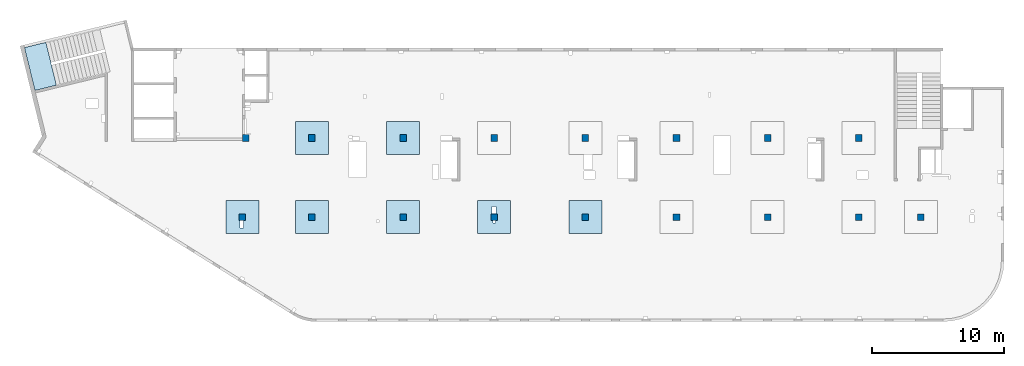
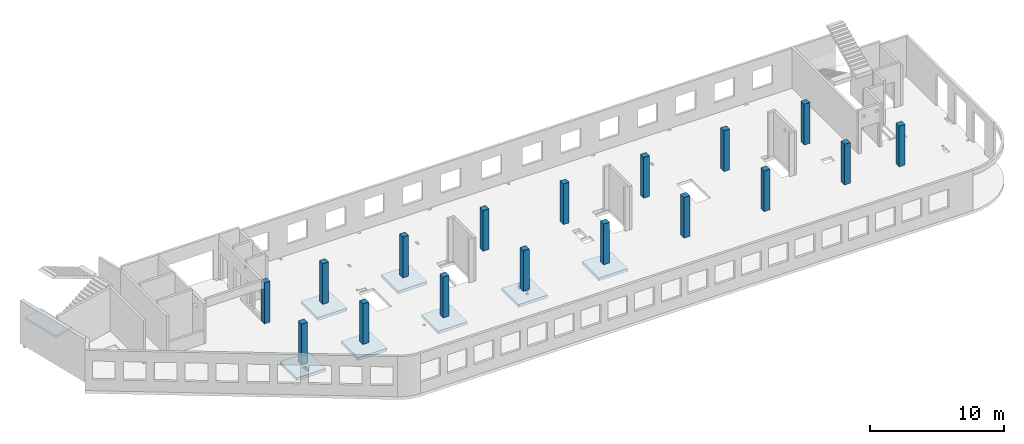
# One storey, part 1 of 6: 17 columns, 8 slabs.
"""IFC4 building model written with IfcOpenShell, lengths in millimetres."""

import ifcopenshell
import ifcopenshell.guid

model = None  # the IFC model being written
_history = None  # IfcOwnerHistory: only IFC2X3 demands one
_inside = {}  # id of a spatial element -> (the spatial element, [elements in it])
_under = {}  # id of a project, library or spatial element -> (it, [spatial elements below it])
_declared = {}  # id of a project -> (the project, [libraries it declares])
_typed = {}  # id of a type object -> (the type object, [elements of that type])
_made_of = {}  # id of a material, layer set ... -> (it, [elements and type objects made of it])


def new_model(schema):
    """Start an empty IFC model of exactly this schema.

    Asked for "IFC4X3", IfcOpenShell would pick the latest addendum, in which some entities
    have other attributes; the version numbers below select the first issue.
    IFC2X3 requires an IfcOwnerHistory on every rooted entity: one is made here for all.
    """
    global model, _history
    if schema == "IFC4X3":
        model = ifcopenshell.file(schema_version=(4, 3, 0, 0))
    else:
        model = ifcopenshell.file(schema=schema)
    _inside.clear()
    _under.clear()
    _declared.clear()
    _typed.clear()
    _made_of.clear()
    _history = None
    if model.schema == "IFC2X3":
        org = make("IfcOrganization", Name="unknown")
        user = make(
            "IfcPersonAndOrganization",
            ThePerson=make("IfcPerson", FamilyName="unknown"),
            TheOrganization=org,
        )
        app = make(
            "IfcApplication",
            ApplicationDeveloper=org,
            Version="unknown",
            ApplicationFullName="unknown",
            ApplicationIdentifier="unknown",
        )
        _history = make(
            "IfcOwnerHistory",
            OwningUser=user,
            OwningApplication=app,
            ChangeAction="ADDED",
            CreationDate=0,
        )
    return model


def make(cls, **values):
    """One entity of the class cls with the attributes given. An attribute that is None is left unset."""
    return model.create_entity(
        cls, **{name: value for name, value in values.items() if value is not None}
    )


def entity(cls, *values):
    """Any entity or typed value of the class cls, its attributes in the order of the schema. None: left unset."""
    e = model.create_entity(cls)
    for i, value in enumerate(values):
        if value is not None:
            e[i] = value
    return e


def rooted(cls, **values):
    """An entity with a GlobalId (a new one), such as an element, a storey or a relation."""
    return make(cls, GlobalId=ifcopenshell.guid.new(), OwnerHistory=_history, **values)


def si_unit(unit_type, name, prefix=None):
    """IfcSIUnit, for example si_unit("LENGTHUNIT", "METRE", prefix="MILLI")."""
    return make("IfcSIUnit", UnitType=unit_type, Prefix=prefix, Name=name)


def converted_unit(unit_type, name, factor, base, dimensions=None, offset=None):
    """IfcConversionBasedUnit, such as the inch: factor (a typed value) times the base unit."""
    return make(
        "IfcConversionBasedUnit"
        if offset is None
        else "IfcConversionBasedUnitWithOffset",
        ConversionOffset=offset,
        Dimensions=None
        if dimensions is None
        else entity("IfcDimensionalExponents", *dimensions),
        UnitType=unit_type,
        Name=name,
        ConversionFactor=make(
            "IfcMeasureWithUnit", ValueComponent=factor, UnitComponent=base
        ),
    )


def derived_unit(unit_type, elements):
    """IfcDerivedUnit: a product of units, each with its exponent."""
    return make(
        "IfcDerivedUnit",
        Elements=[
            make("IfcDerivedUnitElement", Unit=unit, Exponent=power)
            for unit, power in elements
        ],
        UnitType=unit_type,
    )


def assignment(units):
    """IfcUnitAssignment: the units of a project."""
    return None if units is None else make("IfcUnitAssignment", Units=units)


def point(xyz):
    """IfcCartesianPoint."""
    return None if xyz is None else make("IfcCartesianPoint", Coordinates=xyz)


def direction(xyz):
    """IfcDirection."""
    return None if xyz is None else make("IfcDirection", DirectionRatios=xyz)


def frame(location, z_axis=None, x_axis=None):
    """IfcAxis2Placement3D, a coordinate frame: its origin and axes. An axis left out is left unset."""
    return make(
        "IfcAxis2Placement3D",
        Location=point(location),
        Axis=direction(z_axis),
        RefDirection=direction(x_axis),
    )


def origin():
    """The frame at (0, 0, 0) with its axes left unset."""
    return frame((0.0, 0.0, 0.0))


def place(relative_to, where):
    """IfcLocalPlacement: puts the frame where relative to a parent placement (None: the world)."""
    return make(
        "IfcLocalPlacement", PlacementRelTo=relative_to, RelativePlacement=where
    )


def context(
    kind, dimensions, precision=None, world=None, true_north=None, identifier=None
):
    """IfcGeometricRepresentationContext, for example the 3D "Model" context."""
    return make(
        "IfcGeometricRepresentationContext",
        ContextIdentifier=identifier,
        ContextType=kind,
        CoordinateSpaceDimension=dimensions,
        Precision=precision,
        WorldCoordinateSystem=world,
        TrueNorth=true_north,
    )


def subcontext(parent, identifier, kind, view, scale=None):
    """IfcGeometricRepresentationSubContext, for example "Body" below "Model"."""
    return make(
        "IfcGeometricRepresentationSubContext",
        ContextIdentifier=identifier,
        ContextType=kind,
        ParentContext=parent,
        TargetScale=scale,
        TargetView=view,
    )


def project(units=None, contexts=None):
    """IfcProject with its units and contexts."""
    return rooted(
        "IfcProject",
        Name="project",
        RepresentationContexts=contexts,
        UnitsInContext=assignment(units),
    )


def spatial(cls, under=None, at=None, **own):
    """A site, building, storey or space (cls), placed at a placement, below another one or the project."""
    s = rooted(cls, ObjectPlacement=at, **own)
    if under is not None:
        _under.setdefault(under.id(), (under, []))[1].append(s)
    return s


def point_list(points):
    """IfcCartesianPointList2D or 3D."""
    cls = (
        "IfcCartesianPointList2D" if len(points[0]) == 2 else "IfcCartesianPointList3D"
    )
    return make(cls, CoordList=points)


def indexed_curve(points, segments=None, self_intersect=None):
    """IfcIndexedPolyCurve: lines and arcs through numbered points (the first is 1)."""
    return make(
        "IfcIndexedPolyCurve",
        Points=point_list(points),
        Segments=segments,
        SelfIntersect=self_intersect,
    )


def outline(outer, holes=None, kind="AREA"):
    """IfcArbitraryClosedProfileDef: a profile drawn as a closed curve; with holes, ...WithVoids."""
    if holes is None:
        return make("IfcArbitraryClosedProfileDef", ProfileType=kind, OuterCurve=outer)
    return make(
        "IfcArbitraryProfileDefWithVoids",
        ProfileType=kind,
        OuterCurve=outer,
        InnerCurves=holes,
    )


def extrude(swept, where, along, depth):
    """IfcExtrudedAreaSolid: the profile swept, set in the frame where, extruded along a direction by depth."""
    return make(
        "IfcExtrudedAreaSolid",
        SweptArea=swept,
        Position=where,
        ExtrudedDirection=direction(along),
        Depth=depth,
    )


def shape(context_of_items, identifier, shape_type, items):
    """IfcShapeRepresentation: the items that make up one representation, for example the "Body"."""
    return make(
        "IfcShapeRepresentation",
        ContextOfItems=context_of_items,
        RepresentationIdentifier=identifier,
        RepresentationType=shape_type,
        Items=items,
    )


def source(mapping_origin, context_of_items, identifier, shape_type, items):
    """IfcRepresentationMap: a shape defined once, which mapped items show again and again."""
    return make(
        "IfcRepresentationMap",
        MappingOrigin=mapping_origin,
        MappedRepresentation=shape(context_of_items, identifier, shape_type, items),
    )


def transform(
    local_origin,
    x_axis=None,
    y_axis=None,
    z_axis=None,
    scale=None,
    scale2=None,
    scale3=None,
    uniform=True,
):
    """IfcCartesianTransformationOperator3D, or its non-uniform kind. x_axis, y_axis, z_axis: its Axis1, 2, 3."""
    if uniform:
        return make(
            "IfcCartesianTransformationOperator3D",
            Axis1=direction(x_axis),
            Axis2=direction(y_axis),
            LocalOrigin=point(local_origin),
            Scale=scale,
            Axis3=direction(z_axis),
        )
    return make(
        "IfcCartesianTransformationOperator3DnonUniform",
        Axis1=direction(x_axis),
        Axis2=direction(y_axis),
        LocalOrigin=point(local_origin),
        Scale=scale,
        Axis3=direction(z_axis),
        Scale2=scale2,
        Scale3=scale3,
    )


def mapped(mapping_source, mapping_target):
    """IfcMappedItem: shows the shape of a source again, moved by a transform."""
    return make(
        "IfcMappedItem", MappingSource=mapping_source, MappingTarget=mapping_target
    )


def material(Name=None, Category=None):
    """IfcMaterial."""
    return make("IfcMaterial", Name=Name, Category=Category)


def made_of(thing, what):
    """Note that an element or type object is made of a material, layer set ...; save() writes the relation."""
    if what is not None:
        _made_of.setdefault(what.id(), (what, []))[1].append(thing)
    return thing


def type_object(cls, material=None, **own):
    """A type object (cls), such as IfcWallType, which elements share."""
    return made_of(rooted(cls, **own), material)


def type_shapes(of_type, sources):
    """Give a type object the sources (RepresentationMaps) that its elements show as mapped items."""
    of_type.RepresentationMaps = sources


def element(
    cls,
    number,
    at=None,
    inside=None,
    cuts=None,
    type_object=None,
    material=None,
    context=None,
    identifier="Body",
    shape_type=None,
    held_by="IfcProductDefinitionShape",
    body=None,
    shapes=None,
    **own,
):
    """One element of the class cls, such as IfcWall. Its Tag is "e" and its number.

    at: its placement. inside: the storey or other place that contains it. cuts: it is an
    opening in that element (IfcRelVoidsElement). A single representation is given by context,
    identifier, shape_type and body (its items); several are given by shapes. held_by: the class
    of the entity that holds the representations. save() writes the other relations.
    """
    e = rooted(cls, Tag="e%d" % number, ObjectPlacement=at, **own)
    if body is not None:
        shapes = [shape(context, identifier, shape_type, body)]
    if shapes is not None:
        e.Representation = make(held_by, Representations=shapes)
    if inside is not None:
        _inside.setdefault(inside.id(), (inside, []))[1].append(e)
    if cuts is not None:
        rooted(
            "IfcRelVoidsElement", RelatingBuildingElement=cuts, RelatedOpeningElement=e
        )
    if type_object is not None:
        _typed.setdefault(type_object.id(), (type_object, []))[1].append(e)
    return made_of(e, material)


def aggregate(whole, parts):
    """IfcRelAggregates: a whole, such as a stair, and the parts it consists of."""
    return rooted("IfcRelAggregates", RelatingObject=whole, RelatedObjects=parts)


def save(model, path):
    """Write the relations noted so far, then the file.

    IfcRelAggregates (storeys below a building ...), IfcRelContainedInSpatialStructure (elements
    in a storey), IfcRelDefinesByType, IfcRelAssociatesMaterial and IfcRelDeclares: one each for
    every whole, place, type object, material and project.
    """
    for whole, parts in _under.values():
        aggregate(whole, parts)
    for where, things in _inside.values():
        rooted(
            "IfcRelContainedInSpatialStructure",
            RelatedElements=things,
            RelatingStructure=where,
        )
    for kind, things in _typed.values():
        rooted("IfcRelDefinesByType", RelatedObjects=things, RelatingType=kind)
    for what, things in _made_of.values():
        rooted("IfcRelAssociatesMaterial", RelatedObjects=things, RelatingMaterial=what)
    for by, libraries in _declared.values():
        rooted("IfcRelDeclares", RelatingContext=by, RelatedDefinitions=libraries)
    model.write(path)


model = new_model("IFC4")

# Units and contexts
model_context = context("Model", 3, precision=0.01, world=origin(), true_north=direction((6.12303176911189e-17, 1.0)))
plan_context = context("Plan", 3, precision=0.01, world=origin(), true_north=direction((6.12303176911189e-17, 1.0)))
body_context = subcontext(model_context, "Body", "Model", "MODEL_VIEW")
ifc_project = project(units=[si_unit("LENGTHUNIT", "METRE", prefix="MILLI"), si_unit("AREAUNIT", "SQUARE_METRE"), si_unit("VOLUMEUNIT", "CUBIC_METRE"), converted_unit("PLANEANGLEUNIT", "DEGREE", entity("IfcRatioMeasure", 0.0174532925199433), si_unit("PLANEANGLEUNIT", "RADIAN"), dimensions=[0, 0, 0, 0, 0, 0, 0]), si_unit("MASSUNIT", "GRAM", prefix="KILO"), derived_unit("MASSDENSITYUNIT", [(si_unit("MASSUNIT", "GRAM", prefix="KILO"), 1), (si_unit("LENGTHUNIT", "METRE"), -3)]), derived_unit("MOMENTOFINERTIAUNIT", [(si_unit("LENGTHUNIT", "METRE"), 4)]), si_unit("TIMEUNIT", "SECOND"), si_unit("FREQUENCYUNIT", "HERTZ"), si_unit("THERMODYNAMICTEMPERATUREUNIT", "DEGREE_CELSIUS"), derived_unit("THERMALTRANSMITTANCEUNIT", [(si_unit("MASSUNIT", "GRAM", prefix="KILO"), 1), (si_unit("THERMODYNAMICTEMPERATUREUNIT", "KELVIN"), -1), (si_unit("TIMEUNIT", "SECOND"), -3)]), derived_unit("VOLUMETRICFLOWRATEUNIT", [(si_unit("LENGTHUNIT", "METRE"), 3), (si_unit("TIMEUNIT", "SECOND"), -1)]), derived_unit("MASSFLOWRATEUNIT", [(si_unit("MASSUNIT", "GRAM", prefix="KILO"), 1), (si_unit("TIMEUNIT", "SECOND"), -1)]), derived_unit("ROTATIONALFREQUENCYUNIT", [(si_unit("TIMEUNIT", "SECOND"), -1)]), si_unit("ELECTRICCURRENTUNIT", "AMPERE"), si_unit("ELECTRICVOLTAGEUNIT", "VOLT"), si_unit("POWERUNIT", "WATT"), si_unit("FORCEUNIT", "NEWTON", prefix="KILO"), si_unit("ILLUMINANCEUNIT", "LUX"), si_unit("LUMINOUSFLUXUNIT", "LUMEN"), si_unit("LUMINOUSINTENSITYUNIT", "CANDELA"), derived_unit("USERDEFINED", [(si_unit("MASSUNIT", "GRAM", prefix="KILO"), -1), (si_unit("LENGTHUNIT", "METRE"), -2), (si_unit("TIMEUNIT", "SECOND"), 3), (si_unit("LUMINOUSFLUXUNIT", "LUMEN"), 1)]), derived_unit("LINEARVELOCITYUNIT", [(si_unit("LENGTHUNIT", "METRE"), 1), (si_unit("TIMEUNIT", "SECOND"), -1)]), si_unit("PRESSUREUNIT", "PASCAL"), derived_unit("USERDEFINED", [(si_unit("LENGTHUNIT", "METRE"), -2), (si_unit("MASSUNIT", "GRAM", prefix="KILO"), 1), (si_unit("TIMEUNIT", "SECOND"), -2)]), derived_unit("LINEARFORCEUNIT", [(si_unit("MASSUNIT", "GRAM", prefix="KILO"), 1), (si_unit("LENGTHUNIT", "METRE"), 1), (si_unit("TIMEUNIT", "SECOND"), -2), (si_unit("LENGTHUNIT", "METRE"), -1)]), derived_unit("PLANARFORCEUNIT", [(si_unit("MASSUNIT", "GRAM", prefix="KILO"), 1), (si_unit("LENGTHUNIT", "METRE"), 1), (si_unit("TIMEUNIT", "SECOND"), -2), (si_unit("LENGTHUNIT", "METRE"), -2)])], contexts=[model_context, plan_context])

# Site, building, storey
site_placement = place(None, origin())
site = spatial("IfcSite", under=ifc_project, at=site_placement, CompositionType="ELEMENT")
building_placement = place(site_placement, origin())
building = spatial("IfcBuilding", under=site, at=building_placement, CompositionType="ELEMENT")
storey_placement = place(building_placement, frame((0.0, 0.0, 12000.0)))
storey = spatial("IfcBuildingStorey", under=building, at=storey_placement, Name="04", CompositionType="ELEMENT", Elevation=12000.0)

# Columns
ifc_material = material()
column_type_1 = type_object("IfcColumnType", PredefinedType="COLUMN", material=ifc_material)
shared_shape_1 = source(origin(), body_context, "Body", "SweptSolid", [
    extrude(outline(indexed_curve([(-249.999999999999, -249.999999999999), (250.000000000001, -249.999999999999), (249.999999999999, 249.999999999999), (-250.000000000001, 249.999999999999), (-249.999999999999, -249.999999999999)], self_intersect=False)), frame((15900.0, 7700.0, 11850.0), z_axis=(0.0, 0.0, 1.0), x_axis=(0.0, -1.0, 0.0)), (0.0, 0.0, 1.0), 3700.0),
])
type_shapes(column_type_1, [shared_shape_1])
placement_1 = place(storey_placement, frame((0.0, 0.0, -12000.0)))
element("IfcColumn", 1, at=placement_1, inside=storey, type_object=column_type_1, PredefinedType="COLUMN", context=body_context, shape_type="MappedRepresentation", body=[
    mapped(shared_shape_1, transform((0.0, 0.0, 0.0), scale=1.0)),
])
column_type_2 = type_object("IfcColumnType", PredefinedType="COLUMN", material=ifc_material)
shared_shape_2 = source(origin(), body_context, "Body", "SweptSolid", [
    extrude(outline(indexed_curve([(-249.999999999999, -249.999999999999), (250.000000000001, -249.999999999999), (249.999999999999, 249.999999999999), (-250.000000000001, 249.999999999999), (-249.999999999999, -249.999999999999)], self_intersect=False)), frame((21170.0, 7700.0, 11850.0), z_axis=(0.0, 0.0, 1.0), x_axis=(0.0, -1.0, 0.0)), (0.0, 0.0, 1.0), 3700.0),
])
type_shapes(column_type_2, [shared_shape_2])
element("IfcColumn", 2, at=placement_1, inside=storey, type_object=column_type_2, PredefinedType="COLUMN", context=body_context, shape_type="MappedRepresentation", body=[
    mapped(shared_shape_2, transform((0.0, 0.0, 0.0), scale=1.0)),
])
column_type_3 = type_object("IfcColumnType", PredefinedType="COLUMN", material=ifc_material)
shared_shape_3 = source(origin(), body_context, "Body", "SweptSolid", [
    extrude(outline(indexed_curve([(-249.999999999999, -249.999999999999), (250.000000000001, -249.999999999999), (250.000000000001, 249.999999999999), (-249.999999999999, 249.999999999999), (-249.999999999999, -249.999999999999)], self_intersect=False)), frame((28070.0, 7700.0, 11850.0), z_axis=(0.0, 0.0, 1.0), x_axis=(0.0, -1.0, 0.0)), (0.0, 0.0, 1.0), 3700.0),
])
type_shapes(column_type_3, [shared_shape_3])
element("IfcColumn", 3, at=placement_1, inside=storey, type_object=column_type_3, PredefinedType="COLUMN", context=body_context, shape_type="MappedRepresentation", body=[
    mapped(shared_shape_3, transform((0.0, 0.0, 0.0), scale=1.0)),
])
column_type_4 = type_object("IfcColumnType", PredefinedType="COLUMN", material=ifc_material)
shared_shape_4 = source(origin(), body_context, "Body", "SweptSolid", [
    extrude(outline(indexed_curve([(-249.999999999999, -249.999999999999), (250.000000000001, -249.999999999999), (249.999999999999, 249.999999999999), (-250.000000000001, 249.999999999999), (-249.999999999999, -249.999999999999)], self_intersect=False)), frame((34970.0, 7700.0, 11850.0), z_axis=(0.0, 0.0, 1.0), x_axis=(0.0, -1.0, 0.0)), (0.0, 0.0, 1.0), 3700.0),
])
type_shapes(column_type_4, [shared_shape_4])
element("IfcColumn", 4, at=placement_1, inside=storey, type_object=column_type_4, PredefinedType="COLUMN", context=body_context, shape_type="MappedRepresentation", body=[
    mapped(shared_shape_4, transform((0.0, 0.0, 0.0), scale=1.0)),
])
column_type_5 = type_object("IfcColumnType", PredefinedType="COLUMN", material=ifc_material)
shared_shape_5 = source(origin(), body_context, "Body", "SweptSolid", [
    extrude(outline(indexed_curve([(-249.999999999999, -250.000000000004), (250.000000000001, -250.000000000004), (250.000000000001, 249.999999999995), (-249.999999999999, 250.000000000004), (-249.999999999999, -250.000000000004)], self_intersect=False)), frame((41870.0, 7700.0, 11850.0), z_axis=(0.0, 0.0, 1.0), x_axis=(0.0, -1.0, 0.0)), (0.0, 0.0, 1.0), 3700.0),
])
type_shapes(column_type_5, [shared_shape_5])
element("IfcColumn", 5, at=placement_1, inside=storey, type_object=column_type_5, PredefinedType="COLUMN", context=body_context, shape_type="MappedRepresentation", body=[
    mapped(shared_shape_5, transform((0.0, 0.0, 0.0), scale=1.0)),
])
column_type_6 = type_object("IfcColumnType", PredefinedType="COLUMN", material=ifc_material)
shared_shape_6 = source(origin(), body_context, "Body", "SweptSolid", [
    extrude(outline(indexed_curve([(-249.999999999999, -250.000000000004), (250.000000000001, -250.000000000004), (249.999999999999, 249.999999999995), (-250.000000000001, 250.000000000004), (-249.999999999999, -250.000000000004)], self_intersect=False)), frame((48770.0, 7700.0, 11850.0), z_axis=(0.0, 0.0, 1.0), x_axis=(0.0, -1.0, 0.0)), (0.0, 0.0, 1.0), 3700.0),
])
type_shapes(column_type_6, [shared_shape_6])
element("IfcColumn", 6, at=placement_1, inside=storey, type_object=column_type_6, PredefinedType="COLUMN", context=body_context, shape_type="MappedRepresentation", body=[
    mapped(shared_shape_6, transform((0.0, 0.0, 0.0), scale=1.0)),
])
column_type_7 = type_object("IfcColumnType", PredefinedType="COLUMN", material=ifc_material)
shared_shape_7 = source(origin(), body_context, "Body", "SweptSolid", [
    extrude(outline(indexed_curve([(-249.999999999999, -250.000000000004), (250.000000000001, -250.000000000004), (250.000000000001, 249.999999999995), (-249.999999999999, 250.000000000004), (-249.999999999999, -250.000000000004)], self_intersect=False)), frame((55670.0, 7700.0, 11850.0), z_axis=(0.0, 0.0, 1.0), x_axis=(0.0, -1.0, 0.0)), (0.0, 0.0, 1.0), 3700.0),
])
type_shapes(column_type_7, [shared_shape_7])
element("IfcColumn", 7, at=placement_1, inside=storey, type_object=column_type_7, PredefinedType="COLUMN", context=body_context, shape_type="MappedRepresentation", body=[
    mapped(shared_shape_7, transform((0.0, 0.0, 0.0), scale=1.0)),
])
column_type_8 = type_object("IfcColumnType", PredefinedType="COLUMN", material=ifc_material)
shared_shape_8 = source(origin(), body_context, "Body", "SweptSolid", [
    extrude(outline(indexed_curve([(-249.999999999999, -250.000000000004), (250.000000000001, -250.000000000004), (249.999999999999, 249.999999999995), (-250.000000000001, 250.000000000004), (-249.999999999999, -250.000000000004)], self_intersect=False)), frame((62570.0, 7700.0, 11850.0), z_axis=(0.0, 0.0, 1.0), x_axis=(0.0, -1.0, 0.0)), (0.0, 0.0, 1.0), 3700.0),
])
type_shapes(column_type_8, [shared_shape_8])
element("IfcColumn", 8, at=placement_1, inside=storey, type_object=column_type_8, PredefinedType="COLUMN", context=body_context, shape_type="MappedRepresentation", body=[
    mapped(shared_shape_8, transform((0.0, 0.0, 0.0), scale=1.0)),
])
column_type_9 = type_object("IfcColumnType", PredefinedType="COLUMN", material=ifc_material)
shared_shape_9 = source(origin(), body_context, "Body", "SweptSolid", [
    extrude(outline(indexed_curve([(-249.999999999999, -250.000000000004), (250.000000000001, -250.000000000004), (249.999999999999, 249.999999999995), (-250.000000000001, 250.000000000004), (-249.999999999999, -250.000000000004)], self_intersect=False)), frame((67270.0, 7700.0, 11850.0), z_axis=(0.0, 0.0, 1.0), x_axis=(0.0, -1.0, 0.0)), (0.0, 0.0, 1.0), 3700.0),
])
type_shapes(column_type_9, [shared_shape_9])
element("IfcColumn", 9, at=placement_1, inside=storey, type_object=column_type_9, PredefinedType="COLUMN", context=body_context, shape_type="MappedRepresentation", body=[
    mapped(shared_shape_9, transform((0.0, 0.0, 0.0), scale=1.0)),
])
column_type_10 = type_object("IfcColumnType", PredefinedType="COLUMN", material=ifc_material)
shared_shape_10 = source(origin(), body_context, "Body", "SweptSolid", [
    extrude(outline(indexed_curve([(-249.999999999999, -250.000000000004), (249.999999999999, -250.000000000004), (249.999999999999, 249.999999999995), (-249.999999999999, 250.000000000004), (-249.999999999999, -250.000000000004)], self_intersect=False)), frame((62570.0, 13700.0, 11850.0), z_axis=(0.0, 0.0, 1.0), x_axis=(0.0, -1.0, 0.0)), (0.0, 0.0, 1.0), 3700.0),
])
type_shapes(column_type_10, [shared_shape_10])
element("IfcColumn", 10, at=placement_1, inside=storey, type_object=column_type_10, PredefinedType="COLUMN", context=body_context, shape_type="MappedRepresentation", body=[
    mapped(shared_shape_10, transform((0.0, 0.0, 0.0), scale=1.0)),
])
column_type_11 = type_object("IfcColumnType", PredefinedType="COLUMN", material=ifc_material)
shared_shape_11 = source(origin(), body_context, "Body", "SweptSolid", [
    extrude(outline(indexed_curve([(-249.999999999999, -250.000000000004), (249.999999999999, -250.000000000004), (249.999999999999, 249.999999999995), (-249.999999999999, 250.000000000004), (-249.999999999999, -250.000000000004)], self_intersect=False)), frame((55670.0, 13700.0, 11850.0), z_axis=(0.0, 0.0, 1.0), x_axis=(0.0, -1.0, 0.0)), (0.0, 0.0, 1.0), 3700.0),
])
type_shapes(column_type_11, [shared_shape_11])
element("IfcColumn", 11, at=placement_1, inside=storey, type_object=column_type_11, PredefinedType="COLUMN", context=body_context, shape_type="MappedRepresentation", body=[
    mapped(shared_shape_11, transform((0.0, 0.0, 0.0), scale=1.0)),
])
column_type_12 = type_object("IfcColumnType", PredefinedType="COLUMN", material=ifc_material)
shared_shape_12 = source(origin(), body_context, "Body", "SweptSolid", [
    extrude(outline(indexed_curve([(-249.999999999999, -250.000000000004), (249.999999999999, -250.000000000004), (249.999999999999, 249.999999999995), (-249.999999999999, 250.000000000004), (-249.999999999999, -250.000000000004)], self_intersect=False)), frame((48770.0, 13700.0, 11850.0), z_axis=(0.0, 0.0, 1.0), x_axis=(0.0, -1.0, 0.0)), (0.0, 0.0, 1.0), 3700.0),
])
type_shapes(column_type_12, [shared_shape_12])
element("IfcColumn", 12, at=placement_1, inside=storey, type_object=column_type_12, PredefinedType="COLUMN", context=body_context, shape_type="MappedRepresentation", body=[
    mapped(shared_shape_12, transform((0.0, 0.0, 0.0), scale=1.0)),
])
column_type_13 = type_object("IfcColumnType", PredefinedType="COLUMN", material=ifc_material)
shared_shape_13 = source(origin(), body_context, "Body", "SweptSolid", [
    extrude(outline(indexed_curve([(-249.999999999999, -250.000000000004), (249.999999999999, -250.000000000004), (249.999999999999, 249.999999999995), (-249.999999999999, 250.000000000004), (-249.999999999999, -250.000000000004)], self_intersect=False)), frame((41870.0, 13700.0, 11850.0), z_axis=(0.0, 0.0, 1.0), x_axis=(0.0, -1.0, 0.0)), (0.0, 0.0, 1.0), 3700.0),
])
type_shapes(column_type_13, [shared_shape_13])
element("IfcColumn", 13, at=placement_1, inside=storey, type_object=column_type_13, PredefinedType="COLUMN", context=body_context, shape_type="MappedRepresentation", body=[
    mapped(shared_shape_13, transform((0.0, 0.0, 0.0), scale=1.0)),
])
column_type_14 = type_object("IfcColumnType", PredefinedType="COLUMN", material=ifc_material)
shared_shape_14 = source(origin(), body_context, "Body", "SweptSolid", [
    extrude(outline(indexed_curve([(-249.999999999999, -249.999999999999), (249.999999999999, -249.999999999999), (249.999999999999, 249.999999999999), (-249.999999999999, 249.999999999999), (-249.999999999999, -249.999999999999)], self_intersect=False)), frame((34970.0, 13700.0, 11850.0), z_axis=(0.0, 0.0, 1.0), x_axis=(0.0, -1.0, 0.0)), (0.0, 0.0, 1.0), 3700.0),
])
type_shapes(column_type_14, [shared_shape_14])
element("IfcColumn", 14, at=placement_1, inside=storey, type_object=column_type_14, PredefinedType="COLUMN", context=body_context, shape_type="MappedRepresentation", body=[
    mapped(shared_shape_14, transform((0.0, 0.0, 0.0), scale=1.0)),
])
column_type_15 = type_object("IfcColumnType", PredefinedType="COLUMN", material=ifc_material)
shared_shape_15 = source(origin(), body_context, "Body", "SweptSolid", [
    extrude(outline(indexed_curve([(-249.999999999999, -249.999999999999), (249.999999999999, -249.999999999999), (249.999999999999, 249.999999999999), (-249.999999999999, 249.999999999999), (-249.999999999999, -249.999999999999)], self_intersect=False)), frame((28070.0, 13700.0, 11850.0), z_axis=(0.0, 0.0, 1.0), x_axis=(0.0, -1.0, 0.0)), (0.0, 0.0, 1.0), 3700.0),
])
type_shapes(column_type_15, [shared_shape_15])
element("IfcColumn", 15, at=placement_1, inside=storey, type_object=column_type_15, PredefinedType="COLUMN", context=body_context, shape_type="MappedRepresentation", body=[
    mapped(shared_shape_15, transform((0.0, 0.0, 0.0), scale=1.0)),
])
column_type_16 = type_object("IfcColumnType", PredefinedType="COLUMN", material=ifc_material)
shared_shape_16 = source(origin(), body_context, "Body", "SweptSolid", [
    extrude(outline(indexed_curve([(-249.999999999999, -249.999999999999), (249.999999999999, -249.999999999999), (249.999999999999, 249.999999999999), (-249.999999999999, 249.999999999999), (-249.999999999999, -249.999999999999)], self_intersect=False)), frame((21170.0, 13700.0, 11850.0), z_axis=(0.0, 0.0, 1.0), x_axis=(0.0, -1.0, 0.0)), (0.0, 0.0, 1.0), 3700.0),
])
type_shapes(column_type_16, [shared_shape_16])
element("IfcColumn", 16, at=placement_1, inside=storey, type_object=column_type_16, PredefinedType="COLUMN", context=body_context, shape_type="MappedRepresentation", body=[
    mapped(shared_shape_16, transform((0.0, 0.0, 0.0), scale=1.0)),
])
column_type_17 = type_object("IfcColumnType", PredefinedType="COLUMN", material=ifc_material)
shared_shape_17 = source(origin(), body_context, "Body", "SweptSolid", [
    extrude(outline(indexed_curve([(-249.999999999999, -249.999999999999), (249.999999999999, -249.999999999999), (249.999999999999, 249.999999999999), (-249.999999999999, 249.999999999999), (-249.999999999999, -249.999999999999)], self_intersect=False)), frame((16160.0, 13700.0, 11850.0), z_axis=(0.0, 0.0, 1.0), x_axis=(0.0, -1.0, 0.0)), (0.0, 0.0, 1.0), 3700.0),
])
type_shapes(column_type_17, [shared_shape_17])
element("IfcColumn", 17, at=placement_1, inside=storey, type_object=column_type_17, PredefinedType="COLUMN", context=body_context, shape_type="MappedRepresentation", body=[
    mapped(shared_shape_17, transform((0.0, 0.0, 0.0), scale=1.0)),
])

# Slabs
slab_type_1 = type_object("IfcSlabType", Name=":ADSK_ 25_250", PredefinedType="FLOOR", material=ifc_material)
placement_2 = place(storey_placement, origin())
element("IfcSlab", 18, at=placement_2, inside=storey, type_object=slab_type_1, material=ifc_material, Name=":ADSK_ 25_250", ObjectType=":ADSK_ 25_250", PredefinedType="FLOOR", context=body_context, shape_type="SweptSolid", body=[
    extrude(outline(indexed_curve([(-999.999999999999, -1250.0), (1500.0, -1250.0), (1500.0, 1250.0), (-999.999999999999, 1250.0), (-1000.0, -1.73258740687743e-12), (-999.999999999999, -1250.0)], self_intersect=False), holes=[indexed_curve([(500.000000000006, 89.9999999999999), (1060.0, 90.0000000000009), (1060.0, -159.999999999999), (500.000000000007, -160.0), (500.000000000006, 89.9999999999999)], self_intersect=False)]), frame((15900.0, 7950.0, -650.0), z_axis=(0.0, 0.0, 1.0), x_axis=(0.0, -1.0, 0.0)), (0.0, 0.0, 1.0), 249.999999999999),
])
slab_type_2 = type_object("IfcSlabType", Name=":ADSK_ 25_250", PredefinedType="FLOOR", material=ifc_material)
element("IfcSlab", 19, at=placement_2, inside=storey, type_object=slab_type_2, material=ifc_material, Name=":ADSK_ 25_250", ObjectType=":ADSK_ 25_250", PredefinedType="FLOOR", context=body_context, shape_type="SweptSolid", body=[
    extrude(outline(indexed_curve([(-1250.0, -1250.0), (1250.0, -1250.0), (1250.0, 1250.0), (-1250.0, 1250.0), (-1250.0, -1250.0)], self_intersect=False)), frame((21170.0, 7700.0, -400.0), z_axis=(0.0, 0.0, -1.0), x_axis=(0.0, 1.0, 0.0)), (0.0, 0.0, 1.0), 249.999999999999),
])
slab_type_3 = type_object("IfcSlabType", Name=":ADSK_ 25_250", PredefinedType="FLOOR", material=ifc_material)
element("IfcSlab", 20, at=placement_2, inside=storey, type_object=slab_type_3, material=ifc_material, Name=":ADSK_ 25_250", ObjectType=":ADSK_ 25_250", PredefinedType="FLOOR", context=body_context, shape_type="SweptSolid", body=[
    extrude(outline(indexed_curve([(-1250.0, -1250.0), (1250.0, -1250.0), (1250.0, 1250.0), (-1250.0, 1250.0), (-1250.0, -1250.0)], self_intersect=False)), frame((28070.0, 7700.0, -400.0), z_axis=(0.0, 0.0, -1.0), x_axis=(0.0, 1.0, 0.0)), (0.0, 0.0, 1.0), 249.999999999999),
])
slab_type_4 = type_object("IfcSlabType", Name=":ADSK_ 25_250", PredefinedType="FLOOR", material=ifc_material)
element("IfcSlab", 21, at=placement_2, inside=storey, type_object=slab_type_4, material=ifc_material, Name=":ADSK_ 25_250", ObjectType=":ADSK_ 25_250", PredefinedType="FLOOR", context=body_context, shape_type="SweptSolid", body=[
    extrude(outline(indexed_curve([(-999.999999999999, -1250.00000000001), (1500.0, -1250.00000000001), (1500.0, 1250.0), (-999.999999999999, 1250.0), (-1000.0, -6.064055924071e-12), (-999.999999999999, -1250.00000000001)], self_intersect=False), holes=[indexed_curve([(500.000000000073, 99.9999999999998), (700.000000000076, 100.0), (700.000000000076, -100.000000000002), (500.000000000074, -100.000000000002), (500.000000000073, 99.9999999999998)], self_intersect=False), indexed_curve([(-549.999999999928, 149.999999999991), (-39.9999999999262, 149.999999999992), (-39.9999999999256, -180.000000000007), (-549.999999999928, -180.000000000008), (-549.999999999928, 149.999999999991)], self_intersect=False)]), frame((34970.0, 7950.0, -650.0), z_axis=(0.0, 0.0, 1.0), x_axis=(0.0, -1.0, 0.0)), (0.0, 0.0, 1.0), 249.999999999999),
])
slab_type_5 = type_object("IfcSlabType", Name=":ADSK_ 25_250", PredefinedType="FLOOR", material=ifc_material)
element("IfcSlab", 22, at=placement_2, inside=storey, type_object=slab_type_5, material=ifc_material, Name=":ADSK_ 25_250", ObjectType=":ADSK_ 25_250", PredefinedType="FLOOR", context=body_context, shape_type="SweptSolid", body=[
    extrude(outline(indexed_curve([(-1250.0, -1250.0), (1250.0, -1250.0), (1250.0, 1250.0), (-1250.0, 1250.0), (-1250.0, -1250.0)], self_intersect=False)), frame((41870.0, 7700.0, -400.0), z_axis=(0.0, 0.0, -1.0), x_axis=(0.0, 1.0, 0.0)), (0.0, 0.0, 1.0), 249.999999999999),
])
slab_type_6 = type_object("IfcSlabType", Name=":ADSK_ 25_250", PredefinedType="FLOOR", material=ifc_material)
element("IfcSlab", 23, at=placement_2, inside=storey, type_object=slab_type_6, material=ifc_material, Name=":ADSK_ 25_250", ObjectType=":ADSK_ 25_250", PredefinedType="FLOOR", context=body_context, shape_type="SweptSolid", body=[
    extrude(outline(indexed_curve([(-1250.0, -1250.0), (1250.0, -1250.0), (1250.0, 1250.0), (-1250.0, 1250.0), (-1250.0, -1250.0)], self_intersect=False)), frame((28070.0, 13700.0, -400.0), z_axis=(0.0, 0.0, -1.0), x_axis=(0.0, 1.0, 0.0)), (0.0, 0.0, 1.0), 249.999999999999),
])
slab_type_7 = type_object("IfcSlabType", Name=":ADSK_ 25_250", PredefinedType="FLOOR", material=ifc_material)
element("IfcSlab", 24, at=placement_2, inside=storey, type_object=slab_type_7, material=ifc_material, Name=":ADSK_ 25_250", ObjectType=":ADSK_ 25_250", PredefinedType="FLOOR", context=body_context, shape_type="SweptSolid", body=[
    extrude(outline(indexed_curve([(-1250.0, -1250.0), (1250.0, -1250.0), (1250.0, 1250.0), (-1250.0, 1250.0), (-1250.0, -1250.0)], self_intersect=False)), frame((21170.0, 13700.0, -400.0), z_axis=(0.0, 0.0, -1.0), x_axis=(0.0, 1.0, 0.0)), (0.0, 0.0, 1.0), 249.999999999999),
])
slab_type_8 = type_object("IfcSlabType", Name=":ADSK_ 25_200", PredefinedType="FLOOR", material=ifc_material)
element("IfcSlab", 25, at=placement_2, inside=storey, type_object=slab_type_8, material=ifc_material, Name=":ADSK_ 25_200", ObjectType=":ADSK_ 25_200", PredefinedType="FLOOR", context=body_context, shape_type="SweptSolid", body=[
    extrude(outline(indexed_curve([(-835.0, -1670.00000000002), (835.0, -1670.00000000002), (835.0, 1670.00000000002), (-835.000000000001, 1670.00000000002), (-835.0, -1670.00000000002)], self_intersect=False)), frame((612.3, 19119.78, 1920.0), z_axis=(0.0, 0.0, -1.0), x_axis=(0.971552058141474, 0.236826092990333, 0.0)), (0.0, 0.0, 1.0), 200.0),
])

save(model, "model.ifc")
